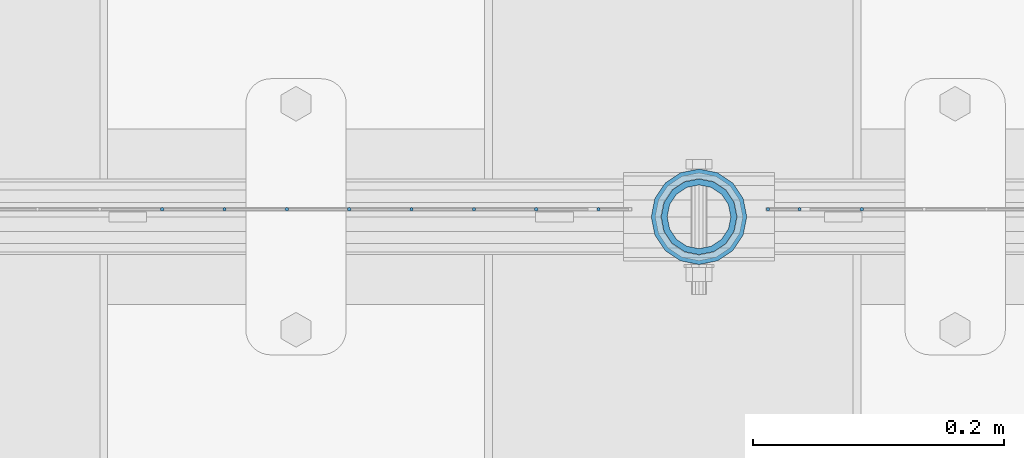
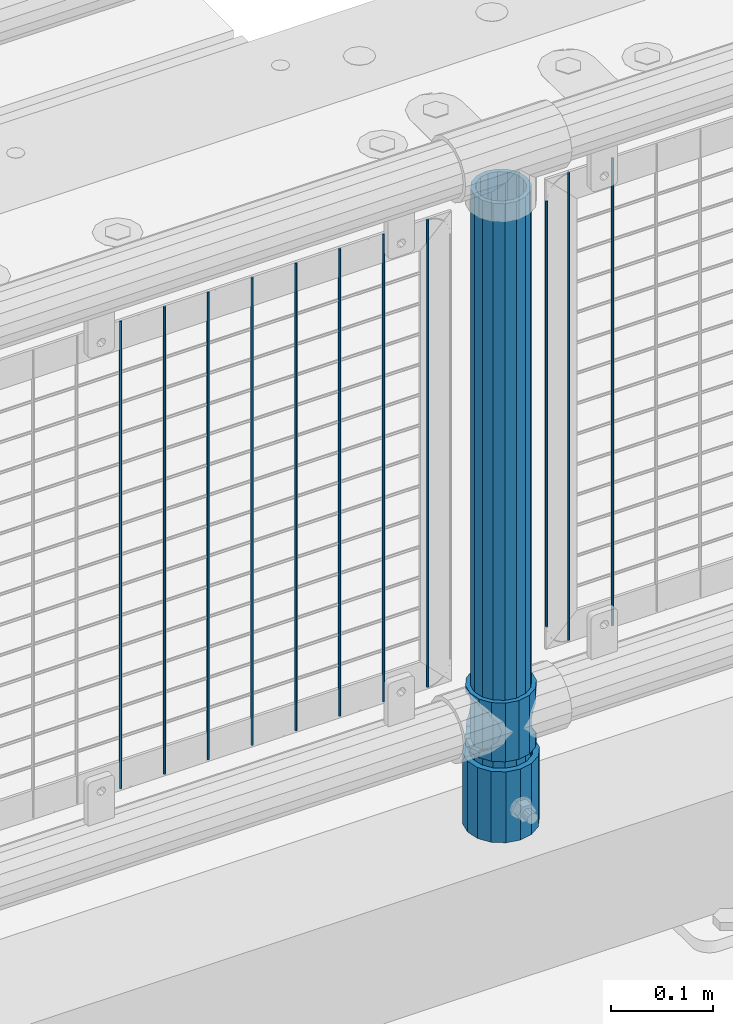
# One storey, part 88 of 257: 14 columns.
"""IFC2X3 building model written with IfcOpenShell, lengths in millimetres."""

from ifc_helpers import new_model, si_unit, frame, origin_with_axes, place, context, subcontext, project, spatial, faceted_brep, material, type_object, element, save


model = new_model("IFC2X3")

# Units and contexts
model_context = context("Model", 3, precision=1e-05, world=origin_with_axes())
body_context = subcontext(model_context, "Body", "Model", "MODEL_VIEW")
ifc_project = project(units=[si_unit("LENGTHUNIT", "METRE", prefix="MILLI"), si_unit("AREAUNIT", "SQUARE_METRE"), si_unit("VOLUMEUNIT", "CUBIC_METRE"), si_unit("MASSUNIT", "GRAM", prefix="KILO"), si_unit("TIMEUNIT", "SECOND"), si_unit("PLANEANGLEUNIT", "RADIAN"), si_unit("SOLIDANGLEUNIT", "STERADIAN"), si_unit("THERMODYNAMICTEMPERATUREUNIT", "DEGREE_CELSIUS"), si_unit("LUMINOUSINTENSITYUNIT", "LUMEN")], contexts=[model_context])

# Site, building, storey
site_placement = place(None, origin_with_axes())
site = spatial("IfcSite", under=ifc_project, at=site_placement, CompositionType="ELEMENT")
building_placement = place(site_placement, origin_with_axes())
building = spatial("IfcBuilding", under=site, at=building_placement, Name="Standard", CompositionType="ELEMENT")
storey_placement = place(building_placement, origin_with_axes())
storey = spatial("IfcBuildingStorey", under=building, at=storey_placement, Name="Undefined", CompositionType="ELEMENT", Elevation=0.0)

# Columns
ifc_material_1 = material()
column_type_1 = type_object("IfcColumnType", PredefinedType="NOTDEFINED")
column_1_placement = place(storey_placement, frame((54271.0, 10664.5, 168.02), z_axis=(0.0, 1.0, 0.0), x_axis=(0.0, 0.0, 1.0)))
element("IfcColumn", 1, at=column_1_placement, inside=storey, type_object=column_type_1, material=ifc_material_1, context=body_context, shape_type="Brep", body=[
    faceted_brep([(0.0, -31.75, 0.0), (0.0, -29.3331751572332, 12.1501989775916), (85.0, -29.3331751572332, 12.1501989775916), (85.0, -31.75, 0.0), (0.0, -22.4506403026753, 22.4506403026735), (85.0, -22.4506403026753, 22.4506403026735), (0.0, -12.1501989775934, 29.3331751572332), (85.0, -12.1501989775934, 29.3331751572332), (0.0, 0.0, 31.75), (85.0, 0.0, 31.75), (0.0, 12.1501989775934, 29.3331751572332), (85.0, 12.1501989775934, 29.3331751572332), (0.0, 22.4506403026753, 22.4506403026735), (85.0, 22.4506403026753, 22.4506403026735), (0.0, 29.3331751572332, 12.1501989775916), (85.0, 29.3331751572332, 12.1501989775916), (0.0, 31.75, 0.0), (85.0, 31.75, 0.0), (0.0, 29.3331751572332, -12.1501989775916), (85.0, 29.3331751572332, -12.1501989775916), (0.0, 22.4506403026753, -22.4506403026735), (85.0, 22.4506403026753, -22.4506403026735), (0.0, 12.1501989775934, -29.3331751572332), (85.0, 12.1501989775934, -29.3331751572332), (0.0, 0.0, -31.75), (85.0, 0.0, -31.75), (0.0, -12.1501989775934, -29.3331751572332), (85.0, -12.1501989775934, -29.3331751572332), (0.0, -22.4506403026753, -22.4506403026735), (85.0, -22.4506403026753, -22.4506403026735), (0.0, -29.3331751572332, -12.1501989775916), (85.0, -29.3331751572332, -12.1501989775916), (0.0, -38.0500000000029, 0.0), (0.0, -35.1536162120537, -14.561104601491), (85.0, -35.1536162120537, -14.561104601491), (85.0, -38.0500000000029, 0.0), (0.0, -26.9054130241493, -26.9054130241475), (85.0, -26.9054130241493, -26.9054130241475), (0.0, -14.5611046014892, -35.1536162120537), (85.0, -14.5611046014892, -35.1536162120537), (0.0, 0.0, -38.0499999999993), (85.0, 0.0, -38.0499999999993), (0.0, 14.5611046014892, -35.1536162120537), (85.0, 14.5611046014892, -35.1536162120537), (0.0, 26.9054130241493, -26.9054130241475), (85.0, 26.9054130241493, -26.9054130241475), (0.0, 35.1536162120537, -14.561104601491), (85.0, 35.1536162120537, -14.561104601491), (0.0, 38.0500000000029, 0.0), (85.0, 38.0500000000029, 0.0), (0.0, 35.1536162120537, 14.561104601491), (85.0, 35.1536162120537, 14.561104601491), (0.0, 26.9054130241493, 26.9054130241475), (85.0, 26.9054130241493, 26.9054130241475), (0.0, 14.5611046014892, 35.1536162120537), (85.0, 14.5611046014892, 35.1536162120537), (0.0, 0.0, 38.0499999999993), (85.0, 0.0, 38.0499999999993), (0.0, -14.5611046014892, 35.1536162120537), (85.0, -14.5611046014892, 35.1536162120537), (0.0, -26.9054130241493, 26.9054130241475), (85.0, -26.9054130241493, 26.9054130241475), (0.0, -35.1536162120537, 14.561104601491), (85.0, -35.1536162120537, 14.561104601491)], [[[0, 1, 2, 3]], [[1, 4, 5, 2]], [[4, 6, 7, 5]], [[6, 8, 9, 7]], [[8, 10, 11, 9]], [[10, 12, 13, 11]], [[12, 14, 15, 13]], [[14, 16, 17, 15]], [[16, 18, 19, 17]], [[18, 20, 21, 19]], [[20, 22, 23, 21]], [[22, 24, 25, 23]], [[24, 26, 27, 25]], [[26, 28, 29, 27]], [[28, 30, 31, 29]], [[30, 0, 3, 31]], [[32, 33, 34, 35]], [[33, 36, 37, 34]], [[36, 38, 39, 37]], [[38, 40, 41, 39]], [[40, 42, 43, 41]], [[42, 44, 45, 43]], [[44, 46, 47, 45]], [[46, 48, 49, 47]], [[48, 50, 51, 49]], [[50, 52, 53, 51]], [[52, 54, 55, 53]], [[54, 56, 57, 55]], [[56, 58, 59, 57]], [[58, 60, 61, 59]], [[60, 62, 63, 61]], [[62, 32, 35, 63]], [[37, 39, 41, 43, 45, 47, 49, 51, 53, 55, 57, 59, 61, 63, 35, 34], [5, 7, 9, 11, 13, 15, 17, 19, 21, 23, 25, 27, 29, 31, 3, 2]], [[62, 60, 58, 56, 54, 52, 50, 48, 46, 44, 42, 40, 38, 36, 33, 32], [30, 28, 26, 24, 22, 20, 18, 16, 14, 12, 10, 8, 6, 4, 1, 0]]]),
])
ifc_material_2 = material(Name="Misc_Undefined")
column_type_2 = type_object("IfcColumnType", PredefinedType="NOTDEFINED")
column_2_placement = place(storey_placement, frame((54271.0, 10664.5, 263.02), z_axis=(-1.0, 0.0, 0.0), x_axis=(0.0, 0.0, 1.0)))
element("IfcColumn", 2, at=column_2_placement, inside=storey, type_object=column_type_2, material=ifc_material_2, context=body_context, shape_type="Brep", body=[
    faceted_brep([(63.1897438117172, 11.6144421722802, -32.8397438117245), (63.1897438117172, 11.6144421722802, -28.0397438117143), (56.6106908090114, 21.4606908090118, -21.4606908090136), (56.6106908090114, 21.4606908090118, -27.1226768591077), (61.9623795176756, 13.4513226476338, -32.4743655677739), (46.7644421722801, 28.0397438117179, -11.6144421722784), (46.7644421722801, 28.0397438117179, -20.0882031229921), (51.5310424080039, 24.8548033587067, -24.8548033587067), (35.1500000000015, 30.35, 0.0), (35.1499999999996, 30.3500000000004, -16.6306603983758), (23.5355578277192, 28.0397438117179, -11.6144421722784), (23.5355578277192, 28.0397438117179, -20.0882031229921), (18.7689575919954, 24.8548033587067, -24.8548033587067), (13.6893091909879, 21.4606908090118, -21.4606908090136), (13.6893091909879, 21.4606908090118, -27.1226768591077), (8.3376204823237, 13.4513226476338, -32.4743655677739), (7.11025618828211, 11.6144421722802, -28.0397438117143), (7.11025618828211, 11.6144421722802, -32.8397438117245), (4.79999999999961, 0.0, -30.3499999999985), (4.79999999999961, 0.0, -35.1500000000015), (7.11025618828205, -11.6144421722802, -28.0397438117143), (7.11025618828205, -11.6144421722802, -32.8397438117245), (13.6893091909879, -21.4606908090118, -21.4606908090136), (13.6893091909879, -21.4606908090118, -27.1226768591077), (8.33762048232484, -13.4513226476338, -32.4743655677739), (23.5355578277191, -28.0397438117179, -11.6144421722784), (23.5355578277191, -28.0397438117179, -20.0882031229849), (18.7689575919987, -24.8548033587067, -24.8548033587067), (35.1500000000015, -30.35, 0.0), (35.1499999999996, -30.3500000000004, -16.6306603983685), (46.7644421722801, -28.0397438117179, -11.6144421722784), (46.7644421722801, -28.0397438117179, -20.0882031229849), (51.5310424080038, -24.8548033587067, -24.8548033587067), (56.6106908090114, -21.4606908090118, -21.4606908090136), (56.6106908090114, -21.4606908090118, -27.1226768591077), (61.9623795176756, -13.4513226476338, -32.4743655677739), (63.1897438117172, -11.6144421722802, -28.0397438117143), (63.1897438117172, -11.6144421722802, -32.8397438117245), (65.4999999999997, 0.0, -30.3499999999985), (65.4999999999997, 0.0, -35.1500000000015), (0.0, -28.0397438117179, -11.6144421722784), (0.0, -30.3500000000004, 0.0), (0.0, -21.4606908090118, -21.4606908090136), (0.0, -11.6144421722802, -28.0397438117143), (0.0, 0.0, -30.3499999999985), (0.0, 11.6144421722802, -28.0397438117143), (0.0, 21.4606908090118, -21.4606908090136), (0.0, 28.0397438117179, -11.6144421722784), (0.0, 30.3500000000004, 0.0), (0.0, 28.0397438117179, 11.6144421722784), (23.5355578277192, 28.0397438117179, 11.6144421722784), (0.0, 21.4606908090118, 21.4606908090136), (13.6893091909879, 21.4606908090118, 21.4606908090136), (0.0, 11.6144421722802, 28.0397438117143), (7.11025618828211, 11.6144421722802, 28.0397438117143), (0.0, 0.0, 30.3499999999985), (4.79999999999961, 0.0, 30.3499999999985), (0.0, -11.6144421722802, 28.0397438117143), (7.11025618828205, -11.6144421722802, 28.0397438117143), (0.0, -21.4606908090118, 21.4606908090136), (13.6893091909879, -21.4606908090118, 21.4606908090136), (0.0, -28.0397438117179, 11.6144421722784), (23.5355578277191, -28.0397438117179, 11.6144421722784), (0.0, -32.4743655677721, 13.4513226476338), (0.0, -35.1499999999996, 0.0), (70.2999999999993, -35.1499999999996, 0.0), (70.2999999999993, -32.4743655677721, 13.4513226476338), (0.0, 13.4513226476338, -32.4743655677739), (0.0, 24.8548033587067, -24.8548033587067), (0.0, 0.0, -35.1499999999996), (0.0, -13.4513226476338, -32.4743655677739), (0.0, -24.8548033587067, -24.8548033587067), (0.0, -24.8548033587067, 24.8548033587067), (0.0, -13.4513226476338, 32.4743655677739), (0.0, 0.0, 35.1499999999996), (0.0, 13.4513226476338, 32.4743655677739), (0.0, 24.8548033587067, 24.8548033587067), (0.0, 32.4743655677721, 13.4513226476338), (0.0, 35.1499999999996, 0.0), (0.0, 32.4743655677721, -13.4513226476338), (0.0, -32.4743655677721, -13.4513226476338), (70.2999999999993, 32.4743655677721, 13.4513226476338), (70.2999999999993, 35.1499999999996, 0.0), (70.2999999999993, 32.4743655677721, -13.4513226476338), (70.2999999999993, 24.8548033587067, -24.8548033587067), (70.2999999999993, 13.4513226476338, -32.4743655677739), (70.2999999999993, 0.0, -35.1500000000015), (70.2999999999993, -13.4513226476338, -32.4743655677739), (70.2999999999993, -24.8548033587067, -24.8548033587067), (70.2999999999993, -32.4743655677721, -13.4513226476338), (70.2999999999993, 28.0397438117179, 11.6144421722784), (70.2999999999993, 21.4606908090118, 21.4606908090136), (56.6106908090114, 21.4606908090118, 21.4606908090136), (46.7644421722801, 28.0397438117179, 11.6144421722784), (70.2999999999993, 11.6144421722802, 28.0397438117143), (63.1897438117172, 11.6144421722802, 28.0397438117143), (70.2999999999993, 0.0, 30.3499999999985), (65.4999999999997, 0.0, 30.3499999999985), (70.2999999999993, -11.6144421722802, 28.0397438117143), (63.1897438117172, -11.6144421722802, 28.0397438117143), (70.2999999999993, -21.4606908090118, 21.4606908090136), (56.6106908090114, -21.4606908090118, 21.4606908090136), (70.2999999999993, -28.0397438117179, 11.6144421722784), (46.7644421722801, -28.0397438117179, 11.6144421722784), (70.2999999999993, -11.6144421722802, -28.0397438117143), (70.2999999999993, 0.0, -30.3499999999985), (70.2999999999993, -21.4606908090118, -21.4606908090136), (70.2999999999993, -28.0397438117179, -11.6144421722784), (70.2999999999993, -30.3500000000004, 0.0), (70.2999999999993, 24.8548033587067, 24.8548033587067), (70.2999999999993, 13.4513226476338, 32.4743655677739), (70.2999999999993, 0.0, 35.1500000000015), (70.2999999999993, -13.4513226476338, 32.4743655677739), (70.2999999999993, -24.8548033587067, 24.8548033587067), (70.2999999999993, 30.3500000000004, 0.0), (70.2999999999993, 28.0397438117179, -11.6144421722784), (70.2999999999993, 21.4606908090118, -21.4606908090136), (70.2999999999993, 11.6144421722802, -28.0397438117143), (61.9623795176756, 13.4513226476338, 32.4743655677739), (51.5310424080039, 24.8548033587067, 24.8548033587067), (56.6106908090114, 21.4606908090118, 27.1226768591077), (65.4999999999997, 0.0, 35.1500000000015), (63.1897438117172, 11.6144421722802, 32.8397438117172), (63.1897438117172, -11.6144421722802, 32.8397438117172), (61.9623795176756, -13.4513226476338, 32.4743655677739), (56.6106908090114, -21.4606908090118, 27.1226768591077), (51.5310424080071, -24.8548033587067, 24.8548033587067), (18.7689575919987, -24.8548033587067, 24.8548033587067), (46.7644421722801, -28.0397438117179, 20.0882031229703), (35.1499999999996, -30.3500000000004, 16.6306603983539), (23.5355578277191, -28.0397438117179, 20.0882031229703), (8.3376204823237, -13.4513226476338, 32.4743655677739), (13.6893091909879, -21.4606908090118, 27.1226768591077), (4.79999999999961, 0.0, 35.1500000000015), (7.11025618828205, -11.6144421722802, 32.8397438117172), (7.11025618828211, 11.6144421722802, 32.8397438117172), (8.3376204823237, 13.4513226476338, 32.4743655677739), (13.6893091909879, 21.4606908090118, 27.1226768591077), (18.7689575919954, 24.8548033587067, 24.8548033587067), (23.5355578277192, 28.0397438117179, 20.0882031229849), (35.1499999999996, 30.3500000000004, 16.6306603983685), (46.7644421722801, 28.0397438117179, 20.0882031229849)], [[[0, 1, 2, 3, 4]], [[3, 2, 5, 6, 7]], [[6, 5, 8, 9]], [[9, 8, 10, 11]], [[12, 11, 10, 13, 14]], [[15, 14, 13, 16, 17]], [[17, 16, 18, 19]], [[19, 18, 20, 21]], [[21, 20, 22, 23, 24]], [[23, 22, 25, 26, 27]], [[26, 25, 28, 29]], [[29, 28, 30, 31]], [[32, 31, 30, 33, 34]], [[35, 34, 33, 36, 37]], [[37, 36, 38, 39]], [[39, 38, 1, 0]], [[40, 41, 28, 25]], [[42, 40, 25, 22]], [[43, 42, 22, 20]], [[44, 43, 20, 18]], [[45, 44, 18, 16]], [[46, 45, 16, 13]], [[47, 46, 13, 10]], [[48, 47, 10, 8]], [[49, 48, 8, 50]], [[51, 49, 50, 52]], [[53, 51, 52, 54]], [[55, 53, 54, 56]], [[57, 55, 56, 58]], [[59, 57, 58, 60]], [[61, 59, 60, 62]], [[41, 61, 62, 28]], [[63, 64, 65, 66]], [[67, 68, 12, 14, 15]], [[69, 67, 15, 17, 19]], [[24, 70, 69, 19, 21]], [[27, 71, 70, 24, 23]], [[63, 72, 73, 74, 75, 76, 77, 78, 79, 68, 67, 69, 70, 71, 80, 64], [40, 42, 43, 44, 45, 46, 47, 48, 49, 51, 53, 55, 57, 59, 61, 41]], [[78, 77, 81, 82]], [[79, 78, 82, 83]], [[9, 11, 12, 68, 79, 83, 84, 7, 6]], [[7, 84, 85, 4, 3]], [[4, 85, 86, 39, 0]], [[87, 88, 32, 34, 35]], [[86, 87, 35, 37, 39]], [[88, 89, 80, 71, 27, 26, 29, 31, 32]], [[64, 80, 89, 65]], [[90, 91, 92, 93]], [[91, 94, 95, 92]], [[94, 96, 97, 95]], [[96, 98, 99, 97]], [[98, 100, 101, 99]], [[100, 102, 103, 101]], [[104, 105, 38, 36]], [[106, 104, 36, 33]], [[107, 106, 33, 30]], [[108, 107, 30, 28]], [[102, 108, 28, 103]], [[88, 87, 86, 85, 84, 83, 82, 81, 109, 110, 111, 112, 113, 66, 65, 89], [100, 98, 96, 94, 91, 90, 114, 115, 116, 117, 105, 104, 106, 107, 108, 102]], [[118, 110, 109, 119, 120]], [[121, 111, 110, 118, 122]], [[112, 111, 121, 123, 124]], [[113, 112, 124, 125, 126]], [[127, 72, 63, 66, 113, 126, 128, 129, 130]], [[131, 73, 72, 127, 132]], [[133, 74, 73, 131, 134]], [[75, 74, 133, 135, 136]], [[76, 75, 136, 137, 138]], [[119, 109, 81, 77, 76, 138, 139, 140, 141]], [[92, 120, 119, 141, 93]], [[95, 122, 118, 120, 92]], [[97, 121, 122, 95]], [[99, 123, 121, 97]], [[101, 125, 124, 123, 99]], [[103, 128, 126, 125, 101]], [[28, 129, 128, 103]], [[62, 130, 129, 28]], [[60, 132, 127, 130, 62]], [[58, 134, 131, 132, 60]], [[56, 133, 134, 58]], [[54, 135, 133, 56]], [[52, 137, 136, 135, 54]], [[50, 139, 138, 137, 52]], [[8, 140, 139, 50]], [[93, 141, 140, 8]], [[114, 90, 93, 8]], [[115, 114, 8, 5]], [[116, 115, 5, 2]], [[117, 116, 2, 1]], [[105, 117, 1, 38]]]),
])
column_type_3 = type_object("IfcColumnType", PredefinedType="NOTDEFINED")
column_3_placement = place(storey_placement, frame((54271.0, 10664.5, 168.02), z_axis=(-1.0, 0.0, 0.0), x_axis=(0.0, 0.0, 1.0)))
element("IfcColumn", 3, at=column_3_placement, inside=storey, type_object=column_type_3, material=ifc_material_1, context=body_context, shape_type="Brep", body=[
    faceted_brep([(0.0, -25.3500000000004, 0.0), (0.0, -23.4203461491616, 9.70102501045767), (760.0, -23.4203461491616, 9.70102501045767), (760.0, -25.3500000000004, 0.0), (0.0, -17.9251569030785, 17.9251569030821), (760.0, -17.9251569030785, 17.9251569030821), (0.0, -9.70102501045585, 23.4203461491634), (760.0, -9.70102501045585, 23.4203461491634), (0.0, 0.0, 25.3499999999985), (760.0, 0.0, 25.3499999999985), (0.0, 9.70102501045585, 23.4203461491634), (760.0, 9.70102501045585, 23.4203461491634), (0.0, 17.9251569030785, 17.9251569030821), (760.0, 17.9251569030785, 17.9251569030821), (0.0, 23.4203461491616, 9.70102501045767), (760.0, 23.4203461491616, 9.70102501045767), (0.0, 25.3500000000004, 0.0), (760.0, 25.3500000000004, 0.0), (0.0, 23.4203461491616, -9.70102501045767), (760.0, 23.4203461491616, -9.70102501045767), (0.0, 17.9251569030785, -17.9251569030821), (760.0, 17.9251569030785, -17.9251569030821), (0.0, 9.70102501045585, -23.4203461491634), (760.0, 9.70102501045585, -23.4203461491634), (0.0, 0.0, -25.3499999999985), (760.0, 0.0, -25.3499999999985), (0.0, -9.70102501045585, -23.4203461491634), (760.0, -9.70102501045585, -23.4203461491634), (0.0, -17.9251569030785, -17.9251569030821), (760.0, -17.9251569030785, -17.9251569030821), (0.0, -23.4203461491616, -9.70102501045767), (760.0, -23.4203461491616, -9.70102501045767), (0.0, -30.1499999999996, 0.0), (0.0, -27.8549679052157, -11.5379054858058), (760.0, -27.8549679052157, -11.5379054858058), (760.0, -30.1499999999996, 0.0), (0.0, -21.3192694527752, -21.3192694527752), (760.0, -21.3192694527752, -21.3192694527752), (0.0, -11.5379054858076, -27.8549679052157), (760.0, -11.5379054858076, -27.8549679052157), (0.0, 0.0, -30.1500000000015), (760.0, 0.0, -30.1500000000015), (0.0, 11.5379054858076, -27.8549679052157), (760.0, 11.5379054858076, -27.8549679052157), (0.0, 21.3192694527752, -21.3192694527752), (760.0, 21.3192694527752, -21.3192694527752), (0.0, 27.8549679052157, -11.5379054858058), (760.0, 27.8549679052157, -11.5379054858058), (0.0, 30.1499999999996, 0.0), (760.0, 30.1499999999996, 0.0), (0.0, 27.8549679052157, 11.5379054858058), (760.0, 27.8549679052157, 11.5379054858058), (0.0, 21.3192694527752, 21.3192694527752), (760.0, 21.3192694527752, 21.3192694527752), (0.0, 11.5379054858076, 27.8549679052157), (760.0, 11.5379054858076, 27.8549679052157), (0.0, 0.0, 30.1500000000015), (760.0, 0.0, 30.1500000000015), (0.0, -11.5379054858076, 27.8549679052157), (760.0, -11.5379054858076, 27.8549679052157), (0.0, -21.3192694527752, 21.3192694527752), (760.0, -21.3192694527752, 21.3192694527752), (0.0, -27.8549679052157, 11.5379054858058), (760.0, -27.8549679052157, 11.5379054858058)], [[[0, 1, 2, 3]], [[1, 4, 5, 2]], [[4, 6, 7, 5]], [[6, 8, 9, 7]], [[8, 10, 11, 9]], [[10, 12, 13, 11]], [[12, 14, 15, 13]], [[14, 16, 17, 15]], [[16, 18, 19, 17]], [[18, 20, 21, 19]], [[20, 22, 23, 21]], [[22, 24, 25, 23]], [[24, 26, 27, 25]], [[26, 28, 29, 27]], [[28, 30, 31, 29]], [[30, 0, 3, 31]], [[32, 33, 34, 35]], [[33, 36, 37, 34]], [[36, 38, 39, 37]], [[38, 40, 41, 39]], [[40, 42, 43, 41]], [[42, 44, 45, 43]], [[44, 46, 47, 45]], [[46, 48, 49, 47]], [[48, 50, 51, 49]], [[50, 52, 53, 51]], [[52, 54, 55, 53]], [[54, 56, 57, 55]], [[56, 58, 59, 57]], [[58, 60, 61, 59]], [[60, 62, 63, 61]], [[62, 32, 35, 63]], [[37, 39, 41, 43, 45, 47, 49, 51, 53, 55, 57, 59, 61, 63, 35, 34], [5, 7, 9, 11, 13, 15, 17, 19, 21, 23, 25, 27, 29, 31, 3, 2]], [[62, 60, 58, 56, 54, 52, 50, 48, 46, 44, 42, 40, 38, 36, 33, 32], [30, 28, 26, 24, 22, 20, 18, 16, 14, 12, 10, 8, 6, 4, 1, 0]]]),
])
column_type_4 = type_object("IfcColumnType", Name="D3", PredefinedType="NOTDEFINED")
column_4_placement = place(storey_placement, frame((54400.6551724138, 10670.5, 353.020000000005), z_axis=(-0.999999999962839, 0.0, 8.62099999968473e-06), x_axis=(8.62099999949798e-06, 0.0, 0.999999999962839)))
element("IfcColumn", 4, at=column_4_placement, inside=storey, type_object=column_type_4, material=ifc_material_2, ObjectType="D3", context=body_context, shape_type="Brep", body=[
    faceted_brep([(0.0, -1.5, -5.6843418860808e-14), (0.0, -0.750000000001819, -1.29903810567669), (560.0, -0.75, -1.29903810567339), (560.0, -1.5, 0.0), (7.27595761418343e-12, 0.749999999998181, -1.29903810567669), (560.0, 0.75, -1.29903810567339), (0.0, 1.5, -5.6843418860808e-14), (560.0, 1.5, 0.0), (7.27595761418343e-12, 0.749999999998181, 1.29903810567669), (560.0, 0.75, 1.29903810567339), (0.0, -0.750000000001819, 1.29903810567669), (560.0, -0.75, 1.29903810567339)], [[[0, 1, 2, 3]], [[1, 4, 5, 2]], [[4, 6, 7, 5]], [[6, 8, 9, 7]], [[8, 10, 11, 9]], [[10, 0, 3, 11]], [[5, 7, 9, 11, 3, 2]], [[10, 8, 6, 4, 1, 0]]]),
])
column_5_placement = place(storey_placement, frame((54326.0, 10670.5, 378.020000000005), z_axis=(-1.0, 0.0, 0.0), x_axis=(0.0, 0.0, 1.0)))
element("IfcColumn", 5, at=column_5_placement, inside=storey, type_object=column_type_4, material=ifc_material_2, ObjectType="D3", context=body_context, shape_type="Brep", body=[
    faceted_brep([(0.0, -1.5, -5.6843418860808e-14), (0.0, -0.750000000001819, -1.29903810567669), (510.0, -0.75, -1.29903810567339), (510.0, -1.5, 0.0), (7.27595761418343e-12, 0.749999999998181, -1.29903810567669), (510.0, 0.75, -1.29903810567339), (0.0, 1.5, -5.6843418860808e-14), (510.0, 1.5, 0.0), (7.27595761418343e-12, 0.749999999998181, 1.29903810567669), (510.0, 0.75, 1.29903810567339), (0.0, -0.750000000001819, 1.29903810567669), (510.0, -0.75, 1.29903810567339)], [[[0, 1, 2, 3]], [[1, 4, 5, 2]], [[4, 6, 7, 5]], [[6, 8, 9, 7]], [[8, 10, 11, 9]], [[10, 0, 3, 11]], [[5, 7, 9, 11, 3, 2]], [[10, 8, 6, 4, 1, 0]]]),
])
for number, where, z_axis, x_axis in (
    (6, (54351.0, 10670.5, 353.020000000005), (-1.0, 0.0, 0.0), (0.0, 0.0, 1.0)),
    (7, (54190.995, 10670.5, 353.020000000004), (-1.0, 0.0, 0.0), (0.0, 0.0, 1.0)),
    (8, (54141.34, 10670.5, 353.020000000004), (-1.0, 0.0, 0.0), (0.0, 0.0, 1.0)),
    (9, (54091.685, 10670.5, 353.020000000004), (-1.0, 0.0, 0.0), (0.0, 0.0, 1.0)),
    (10, (54042.03, 10670.5, 353.020000000004), (-1.0, 0.0, 0.0), (0.0, 0.0, 1.0)),
    (11, (53992.375, 10670.5, 353.020000000004), (-1.0, 0.0, 0.0), (0.0, 0.0, 1.0)),
    (12, (53942.72, 10670.5, 353.020000000004), (-1.0, 0.0, 0.0), (0.0, 0.0, 1.0)),
    (13, (53893.065, 10670.5, 353.020000000004), (-1.0, 0.0, 0.0), (0.0, 0.0, 1.0)),
    (14, (53843.41, 10670.5, 353.020000000004), (-1.0, 0.0, 0.0), (0.0, 0.0, 1.0)),
):
    element("IfcColumn", number, at=place(storey_placement, frame(where, z_axis=z_axis, x_axis=x_axis)), inside=storey, type_object=column_type_4, material=ifc_material_2, ObjectType="D3", context=body_context, shape_type="Brep", body=[
        faceted_brep([(0.0, -1.5, -5.6843418860808e-14), (0.0, -0.750000000001819, -1.29903810567669), (560.0, -0.75, -1.29903810567339), (560.0, -1.5, 0.0), (7.27595761418343e-12, 0.749999999998181, -1.29903810567669), (560.0, 0.75, -1.29903810567339), (0.0, 1.5, -5.6843418860808e-14), (560.0, 1.5, 0.0), (7.27595761418343e-12, 0.749999999998181, 1.29903810567669), (560.0, 0.75, 1.29903810567339), (0.0, -0.750000000001819, 1.29903810567669), (560.0, -0.75, 1.29903810567339)], [[[0, 1, 2, 3]], [[1, 4, 5, 2]], [[4, 6, 7, 5]], [[6, 8, 9, 7]], [[8, 10, 11, 9]], [[10, 0, 3, 11]], [[5, 7, 9, 11, 3, 2]], [[10, 8, 6, 4, 1, 0]]]),
    ])

save(model, "model.ifc")
